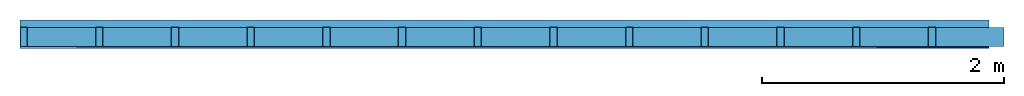
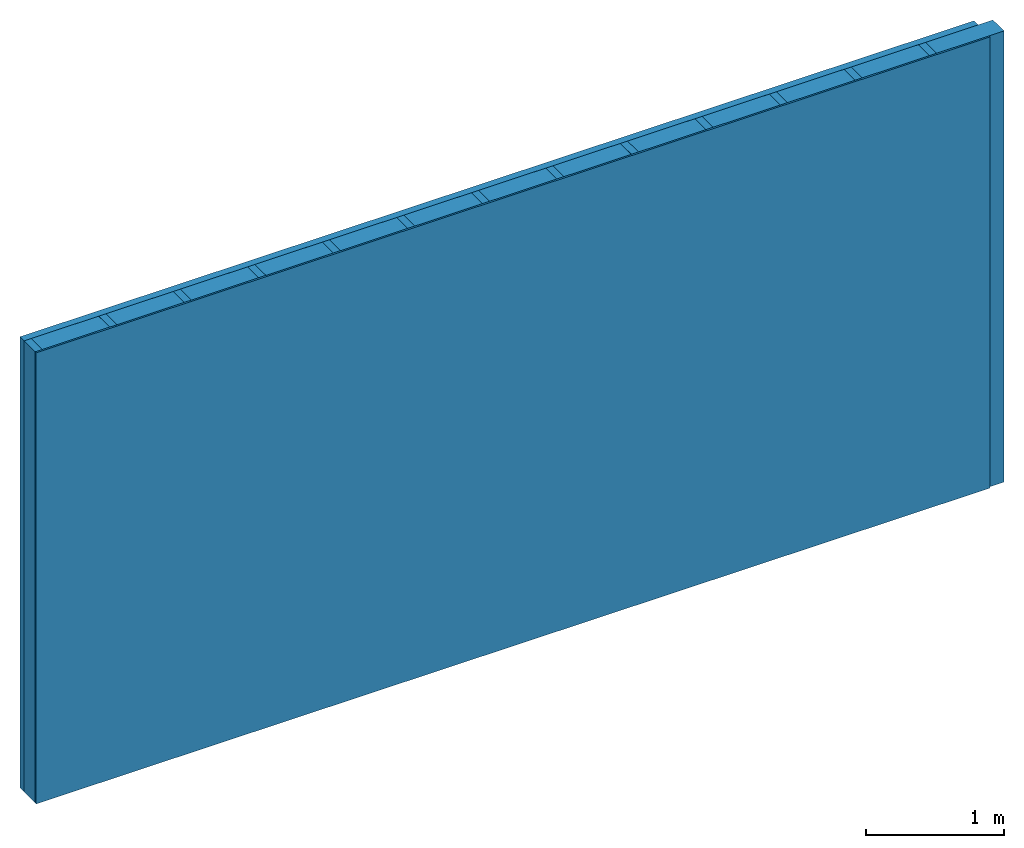
# One storey: 2 members, 2 plates, 1 element without a shape of its own.
"""IFC4 building model written with IfcOpenShell, lengths in metres."""

from ifc_helpers import new_model, si_unit, derived_unit, direction, frame, frame_2d, origin, origin_with_axes, place, context, project, spatial, rectangle, extrude, material, layer, layer_set, type_object, element, aggregate, save


model = new_model("IFC4")

# Units and contexts
plan_context = context("Plan", 3, precision=1e-05, world=origin(), true_north=direction((0.0, 1.0)))
model_context = context("Model", 3, precision=1e-05, world=origin(), true_north=direction((0.0, 1.0)))
ifc_project = project(units=[si_unit("LENGTHUNIT", "METRE"), derived_unit("SOUNDPRESSUREUNIT", [(si_unit("PRESSUREUNIT", "PASCAL", prefix="MICRO"), 0)]), si_unit("ENERGYUNIT", "JOULE", prefix="MEGA"), si_unit("MASSUNIT", "GRAM", prefix="KILO"), derived_unit("THERMALTRANSMITTANCEUNIT", [(si_unit("POWERUNIT", "WATT"), 1), (si_unit("AREAUNIT", "SQUARE_METRE"), -1), (si_unit("THERMODYNAMICTEMPERATUREUNIT", "KELVIN"), -1)]), derived_unit("AREADENSITYUNIT", [(si_unit("MASSUNIT", "GRAM", prefix="KILO"), 1), (si_unit("AREAUNIT", "SQUARE_METRE"), -1)]), derived_unit("USERDEFINED", [(si_unit("ENERGYUNIT", "JOULE", prefix="MEGA"), 1), (si_unit("AREAUNIT", "SQUARE_METRE"), -1)])], contexts=[plan_context, model_context])

# Site, building, storey
site = spatial("IfcSite", under=ifc_project)
building_placement = place(None, origin())
building = spatial("IfcBuilding", under=site, at=building_placement)
storey_placement = place(building_placement, origin())
storey = spatial("IfcBuildingStorey", under=building, at=storey_placement)

# Wall, members, plates
ifc_material_1 = material(Category="10.009")
ifc_layer_1 = layer(ifc_material_1, 0.06, Name="outside 2nd layer")
ifc_material_2 = material(Name="of the art")
ifc_layer_2 = layer(ifc_material_2, 0.0, Name="Bond")
ifc_layer_3 = layer(None, 0.16, Name="Support")
ifc_material_3 = material(Name="Rigid, of the art")
ifc_layer_4 = layer(ifc_material_3, 0.0, Name="Bond")
ifc_material_4 = material(Name="OSB/3", Category="07.013")
ifc_layer_5 = layer(ifc_material_4, 0.015, Name="1st layer")
ifc_layer_set = layer_set([ifc_layer_1, ifc_layer_2, ifc_layer_3, ifc_layer_4, ifc_layer_5])
wall_type = type_object("IfcWallType", Name="D1185", PredefinedType="NOTDEFINED", material=ifc_layer_set)
wall_placement = place(None, frame((0.0, 0.0, 0.0), z_axis=(0.0, -1.0, 0.0), x_axis=(1.0, 0.0, 0.0)))
wall = element("IfcWall", 1, at=wall_placement, inside=storey, type_object=wall_type, material=ifc_layer_set, Name="Wall #1")
ifc_material_5 = material()
member_1_placement = place(wall_placement, origin())
member_1 = element("IfcMember", 2, at=member_1_placement, material=ifc_material_5, Name="Support", context=plan_context, shape_type="SweptSolid", body=[
    extrude(rectangle(XDim=0.06, YDim=0.16, at=frame_2d((0.03, 0.08), x_axis=(1.0, 0.0))), frame((0.0, 4.0, 0.06), z_axis=(0.0, -1.0, 0.0), x_axis=(1.0, 0.0, 0.0)), (0.0, 0.0, 1.0), 4.0),
    extrude(rectangle(XDim=0.06, YDim=0.16, at=frame_2d((0.03, 0.08), x_axis=(1.0, 0.0))), frame((0.625, 4.0, 0.06), z_axis=(0.0, -1.0, 0.0), x_axis=(1.0, 0.0, 0.0)), (0.0, 0.0, 1.0), 4.0),
    extrude(rectangle(XDim=0.06, YDim=0.16, at=frame_2d((0.03, 0.08), x_axis=(1.0, 0.0))), frame((1.25, 4.0, 0.06), z_axis=(0.0, -1.0, 0.0), x_axis=(1.0, 0.0, 0.0)), (0.0, 0.0, 1.0), 4.0),
    extrude(rectangle(XDim=0.06, YDim=0.16, at=frame_2d((0.03, 0.08), x_axis=(1.0, 0.0))), frame((1.875, 4.0, 0.06), z_axis=(0.0, -1.0, 0.0), x_axis=(1.0, 0.0, 0.0)), (0.0, 0.0, 1.0), 4.0),
    extrude(rectangle(XDim=0.06, YDim=0.16, at=frame_2d((0.03, 0.08), x_axis=(1.0, 0.0))), frame((2.5, 4.0, 0.06), z_axis=(0.0, -1.0, 0.0), x_axis=(1.0, 0.0, 0.0)), (0.0, 0.0, 1.0), 4.0),
    extrude(rectangle(XDim=0.06, YDim=0.16, at=frame_2d((0.03, 0.08), x_axis=(1.0, 0.0))), frame((3.125, 4.0, 0.06), z_axis=(0.0, -1.0, 0.0), x_axis=(1.0, 0.0, 0.0)), (0.0, 0.0, 1.0), 4.0),
    extrude(rectangle(XDim=0.06, YDim=0.16, at=frame_2d((0.03, 0.08), x_axis=(1.0, 0.0))), frame((3.75, 4.0, 0.06), z_axis=(0.0, -1.0, 0.0), x_axis=(1.0, 0.0, 0.0)), (0.0, 0.0, 1.0), 4.0),
    extrude(rectangle(XDim=0.06, YDim=0.16, at=frame_2d((0.03, 0.08), x_axis=(1.0, 0.0))), frame((4.375, 4.0, 0.06), z_axis=(0.0, -1.0, 0.0), x_axis=(1.0, 0.0, 0.0)), (0.0, 0.0, 1.0), 4.0),
    extrude(rectangle(XDim=0.06, YDim=0.16, at=frame_2d((0.03, 0.08), x_axis=(1.0, 0.0))), frame((5.0, 4.0, 0.06), z_axis=(0.0, -1.0, 0.0), x_axis=(1.0, 0.0, 0.0)), (0.0, 0.0, 1.0), 4.0),
    extrude(rectangle(XDim=0.06, YDim=0.16, at=frame_2d((0.03, 0.08), x_axis=(1.0, 0.0))), frame((5.625, 4.0, 0.06), z_axis=(0.0, -1.0, 0.0), x_axis=(1.0, 0.0, 0.0)), (0.0, 0.0, 1.0), 4.0),
    extrude(rectangle(XDim=0.06, YDim=0.16, at=frame_2d((0.03, 0.08), x_axis=(1.0, 0.0))), frame((6.25, 4.0, 0.06), z_axis=(0.0, -1.0, 0.0), x_axis=(1.0, 0.0, 0.0)), (0.0, 0.0, 1.0), 4.0),
    extrude(rectangle(XDim=0.06, YDim=0.16, at=frame_2d((0.03, 0.08), x_axis=(1.0, 0.0))), frame((6.875, 4.0, 0.06), z_axis=(0.0, -1.0, 0.0), x_axis=(1.0, 0.0, 0.0)), (0.0, 0.0, 1.0), 4.0),
    extrude(rectangle(XDim=0.06, YDim=0.16, at=frame_2d((0.03, 0.08), x_axis=(1.0, 0.0))), frame((7.5, 4.0, 0.06), z_axis=(0.0, -1.0, 0.0), x_axis=(1.0, 0.0, 0.0)), (0.0, 0.0, 1.0), 4.0),
])
ifc_material_6 = material()
member_2_placement = place(wall_placement, origin())
member_2 = element("IfcMember", 3, at=member_2_placement, material=ifc_material_6, Name="Cavity", context=plan_context, shape_type="SweptSolid", body=[
    extrude(rectangle(XDim=0.565, YDim=0.16, at=frame_2d((0.2825, 0.08), x_axis=(1.0, 0.0))), frame((0.06, 4.0, 0.06), z_axis=(0.0, -1.0, 0.0), x_axis=(1.0, 0.0, 0.0)), (0.0, 0.0, 1.0), 4.0),
    extrude(rectangle(XDim=0.565, YDim=0.16, at=frame_2d((0.2825, 0.08), x_axis=(1.0, 0.0))), frame((0.685, 4.0, 0.06), z_axis=(0.0, -1.0, 0.0), x_axis=(1.0, 0.0, 0.0)), (0.0, 0.0, 1.0), 4.0),
    extrude(rectangle(XDim=0.565, YDim=0.16, at=frame_2d((0.2825, 0.08), x_axis=(1.0, 0.0))), frame((1.31, 4.0, 0.06), z_axis=(0.0, -1.0, 0.0), x_axis=(1.0, 0.0, 0.0)), (0.0, 0.0, 1.0), 4.0),
    extrude(rectangle(XDim=0.565, YDim=0.16, at=frame_2d((0.2825, 0.08), x_axis=(1.0, 0.0))), frame((1.935, 4.0, 0.06), z_axis=(0.0, -1.0, 0.0), x_axis=(1.0, 0.0, 0.0)), (0.0, 0.0, 1.0), 4.0),
    extrude(rectangle(XDim=0.565, YDim=0.16, at=frame_2d((0.2825, 0.08), x_axis=(1.0, 0.0))), frame((2.56, 4.0, 0.06), z_axis=(0.0, -1.0, 0.0), x_axis=(1.0, 0.0, 0.0)), (0.0, 0.0, 1.0), 4.0),
    extrude(rectangle(XDim=0.565, YDim=0.16, at=frame_2d((0.2825, 0.08), x_axis=(1.0, 0.0))), frame((3.185, 4.0, 0.06), z_axis=(0.0, -1.0, 0.0), x_axis=(1.0, 0.0, 0.0)), (0.0, 0.0, 1.0), 4.0),
    extrude(rectangle(XDim=0.565, YDim=0.16, at=frame_2d((0.2825, 0.08), x_axis=(1.0, 0.0))), frame((3.81, 4.0, 0.06), z_axis=(0.0, -1.0, 0.0), x_axis=(1.0, 0.0, 0.0)), (0.0, 0.0, 1.0), 4.0),
    extrude(rectangle(XDim=0.565, YDim=0.16, at=frame_2d((0.2825, 0.08), x_axis=(1.0, 0.0))), frame((4.435, 4.0, 0.06), z_axis=(0.0, -1.0, 0.0), x_axis=(1.0, 0.0, 0.0)), (0.0, 0.0, 1.0), 4.0),
    extrude(rectangle(XDim=0.565, YDim=0.16, at=frame_2d((0.2825, 0.08), x_axis=(1.0, 0.0))), frame((5.06, 4.0, 0.06), z_axis=(0.0, -1.0, 0.0), x_axis=(1.0, 0.0, 0.0)), (0.0, 0.0, 1.0), 4.0),
    extrude(rectangle(XDim=0.565, YDim=0.16, at=frame_2d((0.2825, 0.08), x_axis=(1.0, 0.0))), frame((5.685, 4.0, 0.06), z_axis=(0.0, -1.0, 0.0), x_axis=(1.0, 0.0, 0.0)), (0.0, 0.0, 1.0), 4.0),
    extrude(rectangle(XDim=0.565, YDim=0.16, at=frame_2d((0.2825, 0.08), x_axis=(1.0, 0.0))), frame((6.31, 4.0, 0.06), z_axis=(0.0, -1.0, 0.0), x_axis=(1.0, 0.0, 0.0)), (0.0, 0.0, 1.0), 4.0),
    extrude(rectangle(XDim=0.565, YDim=0.16, at=frame_2d((0.2825, 0.08), x_axis=(1.0, 0.0))), frame((6.935, 4.0, 0.06), z_axis=(0.0, -1.0, 0.0), x_axis=(1.0, 0.0, 0.0)), (0.0, 0.0, 1.0), 4.0),
    extrude(rectangle(XDim=0.565, YDim=0.16, at=frame_2d((0.2825, 0.08), x_axis=(1.0, 0.0))), frame((7.56, 4.0, 0.06), z_axis=(0.0, -1.0, 0.0), x_axis=(1.0, 0.0, 0.0)), (0.0, 0.0, 1.0), 4.0),
])
plate_1_placement = place(wall_placement, origin())
plate_1 = element("IfcPlate", 4, at=plate_1_placement, material=ifc_material_1, Name="outside 2nd layer", context=plan_context, shape_type="SweptSolid", body=[
    extrude(rectangle(XDim=8.0, YDim=4.0, at=frame_2d((4.0, 2.0), x_axis=(1.0, 0.0))), origin_with_axes(), (0.0, 0.0, 1.0), 0.06),
])
plate_2_placement = place(wall_placement, origin())
plate_2 = element("IfcPlate", 5, at=plate_2_placement, material=ifc_material_4, Name="1st layer", context=plan_context, shape_type="SweptSolid", body=[
    extrude(rectangle(XDim=8.0, YDim=4.0, at=frame_2d((4.0, 2.0), x_axis=(1.0, 0.0))), frame((0.0, 0.0, 0.22), z_axis=(0.0, 0.0, 1.0), x_axis=(1.0, 0.0, 0.0)), (0.0, 0.0, 1.0), 0.015),
])
aggregate(wall, [plate_1, member_1, member_2, plate_2])

save(model, "model.ifc")
